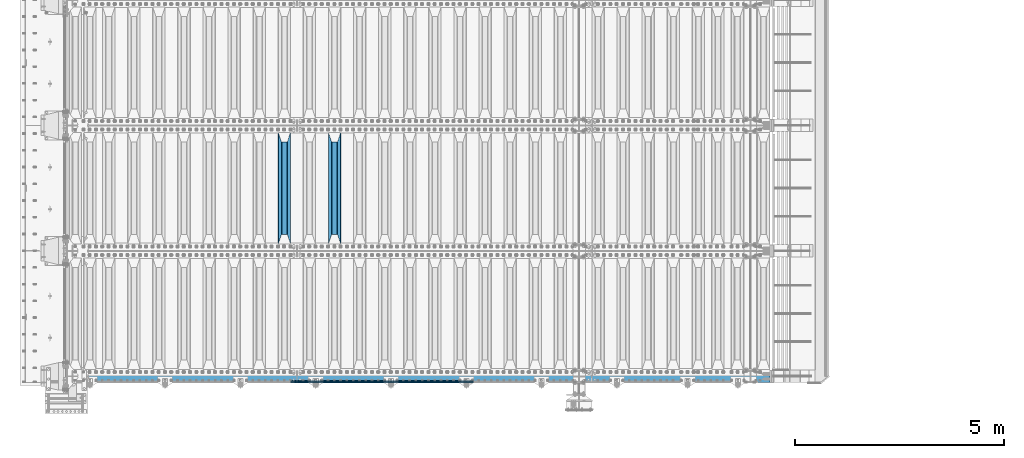
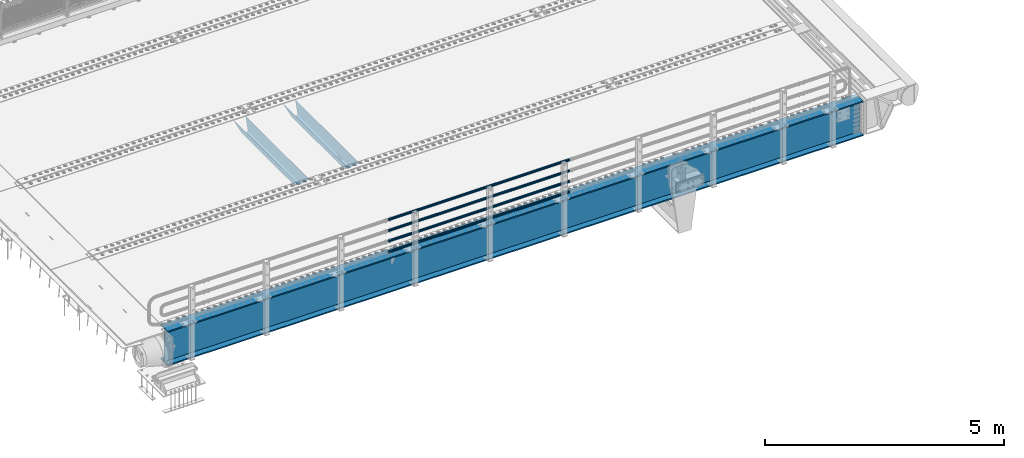
# One storey, part 106 of 257: 7 beams.
"""IFC2X3 building model written with IfcOpenShell, lengths in millimetres."""

import ifcopenshell
import ifcopenshell.guid

model = None  # the IFC model being written
_history = None  # IfcOwnerHistory: only IFC2X3 demands one
_inside = {}  # id of a spatial element -> (the spatial element, [elements in it])
_under = {}  # id of a project, library or spatial element -> (it, [spatial elements below it])
_declared = {}  # id of a project -> (the project, [libraries it declares])
_typed = {}  # id of a type object -> (the type object, [elements of that type])
_made_of = {}  # id of a material, layer set ... -> (it, [elements and type objects made of it])


def new_model(schema):
    """Start an empty IFC model of exactly this schema.

    Asked for "IFC4X3", IfcOpenShell would pick the latest addendum, in which some entities
    have other attributes; the version numbers below select the first issue.
    IFC2X3 requires an IfcOwnerHistory on every rooted entity: one is made here for all.
    """
    global model, _history
    if schema == "IFC4X3":
        model = ifcopenshell.file(schema_version=(4, 3, 0, 0))
    else:
        model = ifcopenshell.file(schema=schema)
    _inside.clear()
    _under.clear()
    _declared.clear()
    _typed.clear()
    _made_of.clear()
    _history = None
    if model.schema == "IFC2X3":
        org = make("IfcOrganization", Name="unknown")
        user = make(
            "IfcPersonAndOrganization",
            ThePerson=make("IfcPerson", FamilyName="unknown"),
            TheOrganization=org,
        )
        app = make(
            "IfcApplication",
            ApplicationDeveloper=org,
            Version="unknown",
            ApplicationFullName="unknown",
            ApplicationIdentifier="unknown",
        )
        _history = make(
            "IfcOwnerHistory",
            OwningUser=user,
            OwningApplication=app,
            ChangeAction="ADDED",
            CreationDate=0,
        )
    return model


def make(cls, **values):
    """One entity of the class cls with the attributes given. An attribute that is None is left unset."""
    return model.create_entity(
        cls, **{name: value for name, value in values.items() if value is not None}
    )


def rooted(cls, **values):
    """An entity with a GlobalId (a new one), such as an element, a storey or a relation."""
    return make(cls, GlobalId=ifcopenshell.guid.new(), OwnerHistory=_history, **values)


def si_unit(unit_type, name, prefix=None):
    """IfcSIUnit, for example si_unit("LENGTHUNIT", "METRE", prefix="MILLI")."""
    return make("IfcSIUnit", UnitType=unit_type, Prefix=prefix, Name=name)


def assignment(units):
    """IfcUnitAssignment: the units of a project."""
    return None if units is None else make("IfcUnitAssignment", Units=units)


def point(xyz):
    """IfcCartesianPoint."""
    return None if xyz is None else make("IfcCartesianPoint", Coordinates=xyz)


def direction(xyz):
    """IfcDirection."""
    return None if xyz is None else make("IfcDirection", DirectionRatios=xyz)


def frame(location, z_axis=None, x_axis=None):
    """IfcAxis2Placement3D, a coordinate frame: its origin and axes. An axis left out is left unset."""
    return make(
        "IfcAxis2Placement3D",
        Location=point(location),
        Axis=direction(z_axis),
        RefDirection=direction(x_axis),
    )


def origin_with_axes():
    """The frame at (0, 0, 0) with the z axis (0, 0, 1) and the x axis (1, 0, 0) written out."""
    return frame((0.0, 0.0, 0.0), z_axis=(0.0, 0.0, 1.0), x_axis=(1.0, 0.0, 0.0))


def place(relative_to, where):
    """IfcLocalPlacement: puts the frame where relative to a parent placement (None: the world)."""
    return make(
        "IfcLocalPlacement", PlacementRelTo=relative_to, RelativePlacement=where
    )


def context(
    kind, dimensions, precision=None, world=None, true_north=None, identifier=None
):
    """IfcGeometricRepresentationContext, for example the 3D "Model" context."""
    return make(
        "IfcGeometricRepresentationContext",
        ContextIdentifier=identifier,
        ContextType=kind,
        CoordinateSpaceDimension=dimensions,
        Precision=precision,
        WorldCoordinateSystem=world,
        TrueNorth=true_north,
    )


def subcontext(parent, identifier, kind, view, scale=None):
    """IfcGeometricRepresentationSubContext, for example "Body" below "Model"."""
    return make(
        "IfcGeometricRepresentationSubContext",
        ContextIdentifier=identifier,
        ContextType=kind,
        ParentContext=parent,
        TargetScale=scale,
        TargetView=view,
    )


def project(units=None, contexts=None):
    """IfcProject with its units and contexts."""
    return rooted(
        "IfcProject",
        Name="project",
        RepresentationContexts=contexts,
        UnitsInContext=assignment(units),
    )


def spatial(cls, under=None, at=None, **own):
    """A site, building, storey or space (cls), placed at a placement, below another one or the project."""
    s = rooted(cls, ObjectPlacement=at, **own)
    if under is not None:
        _under.setdefault(under.id(), (under, []))[1].append(s)
    return s


def faces_of(points, faces, orient=None, outer=None):
    """IfcFace entities. A face is a list of loops; a loop is a list of indices into points, from 0.

    orient and outer hold one flag for each loop. By default every Orientation is true, the
    first loop of a face is its IfcFaceOuterBound and the others are IfcFaceBound.
    """
    made = []
    for i, loops in enumerate(faces):
        bounds = []
        for j, loop in enumerate(loops):
            is_outer = j == 0 if outer is None else outer[i][j]
            bounds.append(
                make(
                    "IfcFaceOuterBound" if is_outer else "IfcFaceBound",
                    Bound=make("IfcPolyLoop", Polygon=[points[k] for k in loop]),
                    Orientation=True if orient is None else orient[i][j],
                )
            )
        made.append(make("IfcFace", Bounds=bounds))
    return made


def faceted_brep(points, faces, orient=None, outer=None, voids=None):
    """IfcFacetedBrep: a solid bounded by flat faces; with voids (closed shells), ...WithVoids."""
    shared = [point(p) for p in points]
    hull = make("IfcClosedShell", CfsFaces=faces_of(shared, faces, orient, outer))
    if voids is None:
        return make("IfcFacetedBrep", Outer=hull)
    return make(
        "IfcFacetedBrepWithVoids",
        Outer=hull,
        Voids=[
            make(cls, CfsFaces=faces_of(shared, fs, o, b)) for cls, fs, o, b in voids
        ],
    )


def shape(context_of_items, identifier, shape_type, items):
    """IfcShapeRepresentation: the items that make up one representation, for example the "Body"."""
    return make(
        "IfcShapeRepresentation",
        ContextOfItems=context_of_items,
        RepresentationIdentifier=identifier,
        RepresentationType=shape_type,
        Items=items,
    )


def material(Name=None, Category=None):
    """IfcMaterial."""
    return make("IfcMaterial", Name=Name, Category=Category)


def made_of(thing, what):
    """Note that an element or type object is made of a material, layer set ...; save() writes the relation."""
    if what is not None:
        _made_of.setdefault(what.id(), (what, []))[1].append(thing)
    return thing


def type_object(cls, material=None, **own):
    """A type object (cls), such as IfcWallType, which elements share."""
    return made_of(rooted(cls, **own), material)


def element(
    cls,
    number,
    at=None,
    inside=None,
    cuts=None,
    type_object=None,
    material=None,
    context=None,
    identifier="Body",
    shape_type=None,
    held_by="IfcProductDefinitionShape",
    body=None,
    shapes=None,
    **own,
):
    """One element of the class cls, such as IfcWall. Its Tag is "e" and its number.

    at: its placement. inside: the storey or other place that contains it. cuts: it is an
    opening in that element (IfcRelVoidsElement). A single representation is given by context,
    identifier, shape_type and body (its items); several are given by shapes. held_by: the class
    of the entity that holds the representations. save() writes the other relations.
    """
    e = rooted(cls, Tag="e%d" % number, ObjectPlacement=at, **own)
    if body is not None:
        shapes = [shape(context, identifier, shape_type, body)]
    if shapes is not None:
        e.Representation = make(held_by, Representations=shapes)
    if inside is not None:
        _inside.setdefault(inside.id(), (inside, []))[1].append(e)
    if cuts is not None:
        rooted(
            "IfcRelVoidsElement", RelatingBuildingElement=cuts, RelatedOpeningElement=e
        )
    if type_object is not None:
        _typed.setdefault(type_object.id(), (type_object, []))[1].append(e)
    return made_of(e, material)


def aggregate(whole, parts):
    """IfcRelAggregates: a whole, such as a stair, and the parts it consists of."""
    return rooted("IfcRelAggregates", RelatingObject=whole, RelatedObjects=parts)


def save(model, path):
    """Write the relations noted so far, then the file.

    IfcRelAggregates (storeys below a building ...), IfcRelContainedInSpatialStructure (elements
    in a storey), IfcRelDefinesByType, IfcRelAssociatesMaterial and IfcRelDeclares: one each for
    every whole, place, type object, material and project.
    """
    for whole, parts in _under.values():
        aggregate(whole, parts)
    for where, things in _inside.values():
        rooted(
            "IfcRelContainedInSpatialStructure",
            RelatedElements=things,
            RelatingStructure=where,
        )
    for kind, things in _typed.values():
        rooted("IfcRelDefinesByType", RelatedObjects=things, RelatingType=kind)
    for what, things in _made_of.values():
        rooted("IfcRelAssociatesMaterial", RelatedObjects=things, RelatingMaterial=what)
    for by, libraries in _declared.values():
        rooted("IfcRelDeclares", RelatingContext=by, RelatedDefinitions=libraries)
    model.write(path)


model = new_model("IFC2X3")

# Units and contexts
model_context = context("Model", 3, precision=1e-05, world=origin_with_axes())
body_context = subcontext(model_context, "Body", "Model", "MODEL_VIEW")
ifc_project = project(units=[si_unit("LENGTHUNIT", "METRE", prefix="MILLI"), si_unit("AREAUNIT", "SQUARE_METRE"), si_unit("VOLUMEUNIT", "CUBIC_METRE"), si_unit("MASSUNIT", "GRAM", prefix="KILO"), si_unit("TIMEUNIT", "SECOND"), si_unit("PLANEANGLEUNIT", "RADIAN"), si_unit("SOLIDANGLEUNIT", "STERADIAN"), si_unit("THERMODYNAMICTEMPERATUREUNIT", "DEGREE_CELSIUS"), si_unit("LUMINOUSINTENSITYUNIT", "LUMEN")], contexts=[model_context])

# Site, building, storey
site_placement = place(None, origin_with_axes())
site = spatial("IfcSite", under=ifc_project, at=site_placement, CompositionType="ELEMENT")
building_placement = place(site_placement, origin_with_axes())
building = spatial("IfcBuilding", under=site, at=building_placement, Name="Standard", CompositionType="ELEMENT")
storey_placement = place(building_placement, origin_with_axes())
storey = spatial("IfcBuildingStorey", under=building, at=storey_placement, Name="Undefined", CompositionType="ELEMENT", Elevation=0.0)

# Beams
ifc_material_1 = material(Name="STEEL/S355N")
beam_type_1 = type_object("IfcBeamType", PredefinedType="NOTDEFINED")
beam_1_placement = place(storey_placement, frame((48850.0, 3175.0, -115.0), z_axis=(0.0, 0.0, 1.0), x_axis=(0.0, 1.0, 0.0)))
element("IfcBeam", 1, at=beam_1_placement, inside=storey, type_object=beam_type_1, material=ifc_material_1, context=body_context, shape_type="Brep", body=[
    faceted_brep([(0.0, 150.0, 115.0), (0.0, 143.690000000002, 115.0), (2650.00000000297, 143.690000000002, 115.0), (2650.00000000297, 150.0, 115.0), (2650.00000000297, 142.059565218406, 110.0000000031), (2650.00000000297, 148.369565218403, 110.0000000031), (2441.90079219208, -80.1103600731149, -98.0992078077845), (2437.7588105432, -77.5672621345584, -102.241189456673), (2434.06523489746, -74.4080125315522, -105.934765102404), (2430.91086095089, -70.7102721255724, -109.089139048974), (2428.37322971128, -66.5649389910031, -111.626770288588), (2426.51472138055, -62.0739139532889, -113.485278619323), (2425.38102192091, -57.3475956567636, -114.618978078955), (2424.99999999987, -52.5021667386536, -115.0), (2424.99999999987, 52.5021667386536, -115.0), (2425.38102192091, 57.3475956567636, -114.618978078955), (2426.51472138055, 62.0739139532889, -113.485278619323), (2428.37322971128, 66.5649389910031, -111.626770288588), (2430.91086095089, 70.7102721255724, -109.089139048974), (2434.06523489746, 74.4080125315522, -105.934765102404), (2437.7588105432, 77.5672621345584, -102.241189456673), (2441.90079219208, 80.1103600731149, -98.0992078077846), (2446.38936140511, 81.9747917625791, -93.6106385947584), (2448.24948500409, 76.2713538057287, -91.7505149957729), (2444.62967112262, 74.76777986261, -95.3703288772456), (2441.28936334126, 72.7168944282894, -98.710636658607), (2438.31067330438, 70.1691124903809, -101.689326695487), (2435.76682334747, 67.1870637758839, -104.233176652398), (2433.72034654133, 63.8440531834931, -106.279653458539), (2432.22154950041, 60.2222587982324, -107.778450499454), (2431.30727574265, 56.4107117849126, -108.692724257221), (2430.99999999987, 52.5031078186876, -109.0), (2430.99999999987, -52.5031078186876, -109.0), (2431.30727574265, -56.4107117849126, -108.692724257221), (2432.22154950041, -60.2222587982324, -107.778450499454), (2433.72034654133, -63.8440531834931, -106.279653458539), (2435.76682334747, -67.1870637758839, -104.233176652398), (2438.31067330438, -70.1691124903809, -101.689326695487), (2441.28936334126, -72.7168944282894, -98.7106366586071), (2444.62967112262, -74.76777986261, -95.3703288772457), (2448.24948500409, -76.2713538057287, -91.7505149957729), (2650.00000000297, -142.059565218406, 110.0000000031), (2650.00000000297, -148.369565218403, 110.0000000031), (2446.38936140511, -81.9747917625791, -93.6106385947584), (2650.00000000297, -143.690000000002, 115.0), (2650.00000000297, -150.0, 115.0), (0.0, -143.690000000002, 115.0), (0.0, -150.0, 115.0), (0.0, -148.369565218258, 110.000000002662), (203.61063859742, -81.9747917625791, -93.6106385947584), (208.099207810447, -80.1103600731149, -98.0992078077845), (212.241189459335, -77.5672621345584, -102.241189456673), (215.934765105066, -74.4080125315522, -105.934765102404), (219.089139051636, -70.7102721255724, -109.089139048974), (221.626770291251, -66.5649389910031, -111.626770288588), (223.485278621985, -62.0739139532889, -113.485278619323), (224.618978081617, -57.3475956567636, -114.618978078955), (225.000000002662, -52.5021667386536, -115.0), (225.000000002662, 52.5021667386536, -115.0), (224.618978081617, 57.3475956567636, -114.618978078955), (223.485278621985, 62.0739139532889, -113.485278619323), (221.626770291251, 66.5649389910031, -111.626770288588), (219.089139051636, 70.7102721255724, -109.089139048974), (215.934765105066, 74.4080125315522, -105.934765102404), (212.241189459335, 77.5672621345584, -102.241189456673), (208.099207810447, 80.1103600731149, -98.0992078077846), (203.61063859742, 81.9747917625791, -93.6106385947584), (0.0, 148.369565218258, 110.000000002662), (0.0, 142.05956521826, 110.000000002662), (201.750514998435, 76.2713538057287, -91.7505149957729), (205.370328879908, 74.76777986261, -95.3703288772456), (208.710636661269, 72.7168944282894, -98.710636658607), (211.689326698149, 70.1691124903809, -101.689326695487), (214.233176655061, 67.1870637758839, -104.233176652398), (216.279653461201, 63.8440531834931, -106.279653458539), (217.778450502116, 60.2222587982324, -107.778450499454), (218.692724259884, 56.4107117849126, -108.692724257221), (219.000000002662, 52.5031078186876, -109.0), (219.000000002662, -52.5031078186876, -109.0), (218.692724259884, -56.4107117849126, -108.692724257221), (217.778450502116, -60.2222587982324, -107.778450499454), (216.279653461201, -63.8440531834931, -106.279653458539), (214.233176655061, -67.1870637758839, -104.233176652398), (211.689326698149, -70.1691124903809, -101.689326695487), (208.710636661269, -72.7168944282894, -98.7106366586071), (205.370328879908, -74.76777986261, -95.3703288772457), (201.750514998435, -76.2713538057287, -91.7505149957729), (0.0, -142.05956521826, 110.000000002662)], [[[0, 1, 2, 3]], [[3, 2, 4, 5]], [[6, 7, 8, 9, 10, 11, 12, 13, 14, 15, 16, 17, 18, 19, 20, 21, 22, 5, 4, 23, 24, 25, 26, 27, 28, 29, 30, 31, 32, 33, 34, 35, 36, 37, 38, 39, 40, 41, 42, 43]], [[44, 45, 42, 41]], [[46, 47, 45, 44]], [[43, 42, 45, 47, 48, 49]], [[6, 43, 49, 50]], [[7, 6, 50, 51]], [[8, 7, 51, 52]], [[9, 8, 52, 53]], [[10, 9, 53, 54]], [[11, 10, 54, 55]], [[12, 11, 55, 56]], [[13, 12, 56, 57]], [[14, 13, 57, 58]], [[15, 14, 58, 59]], [[16, 15, 59, 60]], [[17, 16, 60, 61]], [[18, 17, 61, 62]], [[19, 18, 62, 63]], [[20, 19, 63, 64]], [[21, 20, 64, 65]], [[22, 21, 65, 66]], [[0, 3, 5, 22, 66, 67]], [[1, 0, 67, 68]], [[23, 4, 2, 1, 68, 69]], [[24, 23, 69, 70]], [[25, 24, 70, 71]], [[26, 25, 71, 72]], [[27, 26, 72, 73]], [[28, 27, 73, 74]], [[29, 28, 74, 75]], [[30, 29, 75, 76]], [[31, 30, 76, 77]], [[32, 31, 77, 78]], [[33, 32, 78, 79]], [[34, 33, 79, 80]], [[35, 34, 80, 81]], [[36, 35, 81, 82]], [[37, 36, 82, 83]], [[38, 37, 83, 84]], [[39, 38, 84, 85]], [[40, 39, 85, 86]], [[46, 44, 41, 40, 86, 87]], [[47, 46, 87, 48]], [[86, 85, 84, 83, 82, 81, 80, 79, 78, 77, 76, 75, 74, 73, 72, 71, 70, 69, 68, 67, 66, 65, 64, 63, 62, 61, 60, 59, 58, 57, 56, 55, 54, 53, 52, 51, 50, 49, 48, 87]]]),
])
beam_2_placement = place(storey_placement, frame((47650.0, 3175.0, -115.0), z_axis=(0.0, 0.0, 1.0), x_axis=(0.0, 1.0, 0.0)))
element("IfcBeam", 2, at=beam_2_placement, inside=storey, type_object=beam_type_1, material=ifc_material_1, context=body_context, shape_type="Brep", body=[
    faceted_brep([(0.0, 150.0, 115.0), (0.0, 143.690000000002, 115.0), (2650.00000000297, 143.690000000002, 115.0), (2650.00000000297, 150.0, 115.0), (2650.00000000297, 142.059565218406, 110.0000000031), (2650.00000000297, 148.369565218403, 110.0000000031), (2441.90079219208, -80.1103600731149, -98.0992078077845), (2437.7588105432, -77.5672621345584, -102.241189456673), (2434.06523489746, -74.4080125315522, -105.934765102404), (2430.91086095089, -70.7102721255724, -109.089139048974), (2428.37322971128, -66.5649389910031, -111.626770288588), (2426.51472138055, -62.0739139532889, -113.485278619323), (2425.38102192091, -57.3475956567636, -114.618978078955), (2424.99999999987, -52.5021667386536, -115.0), (2424.99999999987, 52.5021667386536, -115.0), (2425.38102192091, 57.3475956567636, -114.618978078955), (2426.51472138055, 62.0739139532889, -113.485278619323), (2428.37322971128, 66.5649389910031, -111.626770288588), (2430.91086095089, 70.7102721255724, -109.089139048974), (2434.06523489746, 74.4080125315522, -105.934765102404), (2437.7588105432, 77.5672621345584, -102.241189456673), (2441.90079219208, 80.1103600731149, -98.0992078077846), (2446.38936140511, 81.9747917625791, -93.6106385947584), (2448.24948500409, 76.2713538057287, -91.7505149957729), (2444.62967112262, 74.76777986261, -95.3703288772456), (2441.28936334126, 72.7168944282894, -98.710636658607), (2438.31067330438, 70.1691124903809, -101.689326695487), (2435.76682334747, 67.1870637758839, -104.233176652398), (2433.72034654133, 63.8440531834931, -106.279653458539), (2432.22154950041, 60.2222587982324, -107.778450499454), (2431.30727574265, 56.4107117849126, -108.692724257221), (2430.99999999987, 52.5031078186876, -109.0), (2430.99999999987, -52.5031078186876, -109.0), (2431.30727574265, -56.4107117849126, -108.692724257221), (2432.22154950041, -60.2222587982324, -107.778450499454), (2433.72034654133, -63.8440531834931, -106.279653458539), (2435.76682334747, -67.1870637758839, -104.233176652398), (2438.31067330438, -70.1691124903809, -101.689326695487), (2441.28936334126, -72.7168944282894, -98.7106366586071), (2444.62967112262, -74.76777986261, -95.3703288772457), (2448.24948500409, -76.2713538057287, -91.7505149957729), (2650.00000000297, -142.059565218406, 110.0000000031), (2650.00000000297, -148.369565218403, 110.0000000031), (2446.38936140511, -81.9747917625791, -93.6106385947584), (2650.00000000297, -143.690000000002, 115.0), (2650.00000000297, -150.0, 115.0), (0.0, -143.690000000002, 115.0), (0.0, -150.0, 115.0), (0.0, -148.369565218258, 110.000000002662), (203.61063859742, -81.9747917625791, -93.6106385947584), (208.099207810447, -80.1103600731149, -98.0992078077845), (212.241189459335, -77.5672621345584, -102.241189456673), (215.934765105066, -74.4080125315522, -105.934765102404), (219.089139051636, -70.7102721255724, -109.089139048974), (221.626770291251, -66.5649389910031, -111.626770288588), (223.485278621985, -62.0739139532889, -113.485278619323), (224.618978081617, -57.3475956567636, -114.618978078955), (225.000000002662, -52.5021667386536, -115.0), (225.000000002662, 52.5021667386536, -115.0), (224.618978081617, 57.3475956567636, -114.618978078955), (223.485278621985, 62.0739139532889, -113.485278619323), (221.626770291251, 66.5649389910031, -111.626770288588), (219.089139051636, 70.7102721255724, -109.089139048974), (215.934765105066, 74.4080125315522, -105.934765102404), (212.241189459335, 77.5672621345584, -102.241189456673), (208.099207810447, 80.1103600731149, -98.0992078077846), (203.61063859742, 81.9747917625791, -93.6106385947584), (0.0, 148.369565218258, 110.000000002662), (0.0, 142.05956521826, 110.000000002662), (201.750514998435, 76.2713538057287, -91.7505149957729), (205.370328879908, 74.76777986261, -95.3703288772456), (208.710636661269, 72.7168944282894, -98.710636658607), (211.689326698149, 70.1691124903809, -101.689326695487), (214.233176655061, 67.1870637758839, -104.233176652398), (216.279653461201, 63.8440531834931, -106.279653458539), (217.778450502116, 60.2222587982324, -107.778450499454), (218.692724259884, 56.4107117849126, -108.692724257221), (219.000000002662, 52.5031078186876, -109.0), (219.000000002662, -52.5031078186876, -109.0), (218.692724259884, -56.4107117849126, -108.692724257221), (217.778450502116, -60.2222587982324, -107.778450499454), (216.279653461201, -63.8440531834931, -106.279653458539), (214.233176655061, -67.1870637758839, -104.233176652398), (211.689326698149, -70.1691124903809, -101.689326695487), (208.710636661269, -72.7168944282894, -98.7106366586071), (205.370328879908, -74.76777986261, -95.3703288772457), (201.750514998435, -76.2713538057287, -91.7505149957729), (0.0, -142.05956521826, 110.000000002662)], [[[0, 1, 2, 3]], [[3, 2, 4, 5]], [[6, 7, 8, 9, 10, 11, 12, 13, 14, 15, 16, 17, 18, 19, 20, 21, 22, 5, 4, 23, 24, 25, 26, 27, 28, 29, 30, 31, 32, 33, 34, 35, 36, 37, 38, 39, 40, 41, 42, 43]], [[44, 45, 42, 41]], [[46, 47, 45, 44]], [[43, 42, 45, 47, 48, 49]], [[6, 43, 49, 50]], [[7, 6, 50, 51]], [[8, 7, 51, 52]], [[9, 8, 52, 53]], [[10, 9, 53, 54]], [[11, 10, 54, 55]], [[12, 11, 55, 56]], [[13, 12, 56, 57]], [[14, 13, 57, 58]], [[15, 14, 58, 59]], [[16, 15, 59, 60]], [[17, 16, 60, 61]], [[18, 17, 61, 62]], [[19, 18, 62, 63]], [[20, 19, 63, 64]], [[21, 20, 64, 65]], [[22, 21, 65, 66]], [[0, 3, 5, 22, 66, 67]], [[1, 0, 67, 68]], [[23, 4, 2, 1, 68, 69]], [[24, 23, 69, 70]], [[25, 24, 70, 71]], [[26, 25, 71, 72]], [[27, 26, 72, 73]], [[28, 27, 73, 74]], [[29, 28, 74, 75]], [[30, 29, 75, 76]], [[31, 30, 76, 77]], [[32, 31, 77, 78]], [[33, 32, 78, 79]], [[34, 33, 79, 80]], [[35, 34, 80, 81]], [[36, 35, 81, 82]], [[37, 36, 82, 83]], [[38, 37, 83, 84]], [[39, 38, 84, 85]], [[40, 39, 85, 86]], [[46, 44, 41, 40, 86, 87]], [[47, 46, 87, 48]], [[86, 85, 84, 83, 82, 81, 80, 79, 78, 77, 76, 75, 74, 73, 72, 71, 70, 69, 68, 67, 66, 65, 64, 63, 62, 61, 60, 59, 58, 57, 56, 55, 54, 53, 52, 51, 50, 49, 48, 87]]]),
])
ifc_material_2 = material()
beam_type_2 = type_object("IfcBeamType", PredefinedType="NOTDEFINED")
beam_3_placement = place(storey_placement, frame((52177.9999999999, -129.849999999907, 149.849999999725), z_axis=(0.0, 0.0, -1.0), x_axis=(-1.0, 0.0, 0.0)))
element("IfcBeam", 3, at=beam_3_placement, inside=storey, type_object=beam_type_2, material=ifc_material_2, context=body_context, shape_type="Brep", body=[
    faceted_brep([(0.0, -26.5499999999993, 0.0), (0.0, -24.5290015881747, 10.1602451292931), (4384.00249699992, -24.5290015881747, 10.1602451292931), (4384.00249699992, -26.5499999999993, 0.0), (0.0, -18.7736850405036, 18.7736850405028), (4384.00249699992, -18.7736850405036, 18.7736850405028), (0.0, -10.1602451292929, 24.5290015881747), (4384.00249699992, -10.1602451292929, 24.5290015881747), (0.0, 0.0, 26.55), (4384.00249699992, 0.0, 26.55), (0.0, 10.1602451292929, 24.5290015881747), (4384.00249699992, 10.1602451292929, 24.5290015881747), (0.0, 18.7736850405036, 18.7736850405028), (4384.00249699992, 18.7736850405036, 18.7736850405028), (0.0, 24.5290015881747, 10.1602451292931), (4384.00249699992, 24.5290015881747, 10.1602451292931), (0.0, 26.5499999999993, 0.0), (4384.00249699992, 26.5499999999993, 0.0), (0.0, 24.5290015881747, -10.1602451292931), (4384.00249699992, 24.5290015881747, -10.1602451292931), (0.0, 18.7736850405036, -18.7736850405028), (4384.00249699992, 18.7736850405036, -18.7736850405028), (0.0, 10.1602451292929, -24.5290015881747), (4384.00249699992, 10.1602451292929, -24.5290015881747), (0.0, 0.0, -26.55), (4384.00249699992, 0.0, -26.55), (0.0, -10.1602451292929, -24.5290015881747), (4384.00249699992, -10.1602451292929, -24.5290015881747), (0.0, -18.7736850405036, -18.7736850405028), (4384.00249699992, -18.7736850405036, -18.7736850405028), (0.0, -24.5290015881747, -10.1602451292931), (4384.00249699992, -24.5290015881747, -10.1602451292931), (0.0, -30.1499999999996, 0.0), (0.0, -27.8549679052157, -11.5379054858058), (4384.00249699992, -27.8549679052157, -11.5379054858075), (4384.00249699992, -30.1499999999996, 0.0), (0.0, -21.3192694527752, -21.3192694527752), (4384.00249699992, -21.3192694527752, -21.3192694527744), (0.0, -11.5379054858076, -27.8549679052157), (4384.00249699992, -11.5379054858076, -27.8549679052153), (0.0, 0.0, -30.1500000000015), (4384.00249699992, 0.0, -30.15), (0.0, 11.5379054858076, -27.8549679052157), (4384.00249699992, 11.5379054858076, -27.8549679052153), (0.0, 21.3192694527752, -21.3192694527752), (4384.00249699992, 21.3192694527752, -21.3192694527744), (0.0, 27.8549679052157, -11.5379054858058), (4384.00249699992, 27.8549679052157, -11.5379054858074), (0.0, 30.1499999999996, 0.0), (4384.00249699992, 30.1499999999996, 0.0), (0.0, 27.8549679052157, 11.5379054858058), (4384.00249699992, 27.8549679052157, 11.5379054858075), (0.0, 21.3192694527752, 21.3192694527752), (4384.00249699992, 21.3192694527752, 21.3192694527744), (0.0, 11.5379054858076, 27.8549679052157), (4384.00249699992, 11.5379054858076, 27.8549679052153), (0.0, 0.0, 30.1500000000015), (4384.00249699992, 0.0, 30.15), (0.0, -11.5379054858076, 27.8549679052157), (4384.00249699992, -11.5379054858076, 27.8549679052153), (0.0, -21.3192694527752, 21.3192694527752), (4384.00249699992, -21.3192694527752, 21.3192694527744), (0.0, -27.8549679052157, 11.5379054858058), (4384.00249699992, -27.8549679052157, 11.5379054858075)], [[[0, 1, 2, 3]], [[1, 4, 5, 2]], [[4, 6, 7, 5]], [[6, 8, 9, 7]], [[8, 10, 11, 9]], [[10, 12, 13, 11]], [[12, 14, 15, 13]], [[14, 16, 17, 15]], [[16, 18, 19, 17]], [[18, 20, 21, 19]], [[20, 22, 23, 21]], [[22, 24, 25, 23]], [[24, 26, 27, 25]], [[26, 28, 29, 27]], [[28, 30, 31, 29]], [[30, 0, 3, 31]], [[32, 33, 34, 35]], [[33, 36, 37, 34]], [[36, 38, 39, 37]], [[38, 40, 41, 39]], [[40, 42, 43, 41]], [[42, 44, 45, 43]], [[44, 46, 47, 45]], [[46, 48, 49, 47]], [[48, 50, 51, 49]], [[50, 52, 53, 51]], [[52, 54, 55, 53]], [[54, 56, 57, 55]], [[56, 58, 59, 57]], [[58, 60, 61, 59]], [[60, 62, 63, 61]], [[62, 32, 35, 63]], [[37, 39, 41, 43, 45, 47, 49, 51, 53, 55, 57, 59, 61, 63, 35, 34], [5, 7, 9, 11, 13, 15, 17, 19, 21, 23, 25, 27, 29, 31, 3, 2]], [[62, 60, 58, 56, 54, 52, 50, 48, 46, 44, 42, 40, 38, 36, 33, 32], [30, 28, 26, 24, 22, 20, 18, 16, 14, 12, 10, 8, 6, 4, 1, 0]]]),
])
beam_4_placement = place(storey_placement, frame((52177.9999999999, -129.849999999907, 420.149999999728), z_axis=(0.0, 0.0, -1.0), x_axis=(-1.0, 0.0, 0.0)))
element("IfcBeam", 4, at=beam_4_placement, inside=storey, type_object=beam_type_2, material=ifc_material_2, context=body_context, shape_type="Brep", body=[
    faceted_brep([(0.0, -26.5499999999993, 0.0), (0.0, -24.5290015881747, 10.1602451292931), (4384.00249699992, -24.5290015881747, 10.1602451292931), (4384.00249699992, -26.5499999999993, 0.0), (0.0, -18.7736850405036, 18.7736850405028), (4384.00249699992, -18.7736850405036, 18.7736850405028), (0.0, -10.1602451292929, 24.5290015881747), (4384.00249699992, -10.1602451292929, 24.5290015881747), (0.0, 0.0, 26.55), (4384.00249699992, 0.0, 26.55), (0.0, 10.1602451292929, 24.5290015881747), (4384.00249699992, 10.1602451292929, 24.5290015881747), (0.0, 18.7736850405036, 18.7736850405028), (4384.00249699992, 18.7736850405036, 18.7736850405028), (0.0, 24.5290015881747, 10.1602451292931), (4384.00249699992, 24.5290015881747, 10.1602451292931), (0.0, 26.5499999999993, 0.0), (4384.00249699992, 26.5499999999993, 0.0), (0.0, 24.5290015881747, -10.1602451292931), (4384.00249699992, 24.5290015881747, -10.1602451292931), (0.0, 18.7736850405036, -18.7736850405028), (4384.00249699992, 18.7736850405036, -18.7736850405028), (0.0, 10.1602451292929, -24.5290015881747), (4384.00249699992, 10.1602451292929, -24.5290015881747), (0.0, 0.0, -26.55), (4384.00249699992, 0.0, -26.55), (0.0, -10.1602451292929, -24.5290015881747), (4384.00249699992, -10.1602451292929, -24.5290015881747), (0.0, -18.7736850405036, -18.7736850405028), (4384.00249699992, -18.7736850405036, -18.7736850405028), (0.0, -24.5290015881747, -10.1602451292931), (4384.00249699992, -24.5290015881747, -10.1602451292931), (0.0, -30.1499999999996, 0.0), (0.0, -27.8549679052157, -11.5379054858058), (4384.00249699992, -27.8549679052157, -11.5379054858075), (4384.00249699992, -30.1499999999996, 0.0), (0.0, -21.3192694527752, -21.3192694527752), (4384.00249699992, -21.3192694527752, -21.3192694527744), (0.0, -11.5379054858076, -27.8549679052157), (4384.00249699992, -11.5379054858076, -27.8549679052153), (0.0, 0.0, -30.1500000000015), (4384.00249699992, 0.0, -30.15), (0.0, 11.5379054858076, -27.8549679052157), (4384.00249699992, 11.5379054858076, -27.8549679052153), (0.0, 21.3192694527752, -21.3192694527752), (4384.00249699992, 21.3192694527752, -21.3192694527744), (0.0, 27.8549679052157, -11.5379054858058), (4384.00249699992, 27.8549679052157, -11.5379054858074), (0.0, 30.1499999999996, 0.0), (4384.00249699992, 30.1499999999996, 0.0), (0.0, 27.8549679052157, 11.5379054858058), (4384.00249699992, 27.8549679052157, 11.5379054858075), (0.0, 21.3192694527752, 21.3192694527752), (4384.00249699992, 21.3192694527752, 21.3192694527744), (0.0, 11.5379054858076, 27.8549679052157), (4384.00249699992, 11.5379054858076, 27.8549679052153), (0.0, 0.0, 30.1500000000015), (4384.00249699992, 0.0, 30.15), (0.0, -11.5379054858076, 27.8549679052157), (4384.00249699992, -11.5379054858076, 27.8549679052153), (0.0, -21.3192694527752, 21.3192694527752), (4384.00249699992, -21.3192694527752, 21.3192694527744), (0.0, -27.8549679052157, 11.5379054858058), (4384.00249699992, -27.8549679052157, 11.5379054858075)], [[[0, 1, 2, 3]], [[1, 4, 5, 2]], [[4, 6, 7, 5]], [[6, 8, 9, 7]], [[8, 10, 11, 9]], [[10, 12, 13, 11]], [[12, 14, 15, 13]], [[14, 16, 17, 15]], [[16, 18, 19, 17]], [[18, 20, 21, 19]], [[20, 22, 23, 21]], [[22, 24, 25, 23]], [[24, 26, 27, 25]], [[26, 28, 29, 27]], [[28, 30, 31, 29]], [[30, 0, 3, 31]], [[32, 33, 34, 35]], [[33, 36, 37, 34]], [[36, 38, 39, 37]], [[38, 40, 41, 39]], [[40, 42, 43, 41]], [[42, 44, 45, 43]], [[44, 46, 47, 45]], [[46, 48, 49, 47]], [[48, 50, 51, 49]], [[50, 52, 53, 51]], [[52, 54, 55, 53]], [[54, 56, 57, 55]], [[56, 58, 59, 57]], [[58, 60, 61, 59]], [[60, 62, 63, 61]], [[62, 32, 35, 63]], [[37, 39, 41, 43, 45, 47, 49, 51, 53, 55, 57, 59, 61, 63, 35, 34], [5, 7, 9, 11, 13, 15, 17, 19, 21, 23, 25, 27, 29, 31, 3, 2]], [[62, 60, 58, 56, 54, 52, 50, 48, 46, 44, 42, 40, 38, 36, 33, 32], [30, 28, 26, 24, 22, 20, 18, 16, 14, 12, 10, 8, 6, 4, 1, 0]]]),
])
beam_5_placement = place(storey_placement, frame((52177.9999999999, -129.849999999907, 969.849999999725), z_axis=(0.0, 0.0, -1.0), x_axis=(-1.0, 0.0, 0.0)))
element("IfcBeam", 5, at=beam_5_placement, inside=storey, type_object=beam_type_2, material=ifc_material_2, context=body_context, shape_type="Brep", body=[
    faceted_brep([(0.0, -26.5499999999993, 0.0), (0.0, -24.5290015881747, 10.1602451292931), (4384.00249699992, -24.5290015881747, 10.1602451292931), (4384.00249699992, -26.5499999999993, 0.0), (0.0, -18.7736850405036, 18.7736850405028), (4384.00249699992, -18.7736850405036, 18.7736850405028), (0.0, -10.1602451292929, 24.5290015881747), (4384.00249699992, -10.1602451292929, 24.5290015881747), (0.0, 0.0, 26.55), (4384.00249699992, 0.0, 26.55), (0.0, 10.1602451292929, 24.5290015881747), (4384.00249699992, 10.1602451292929, 24.5290015881747), (0.0, 18.7736850405036, 18.7736850405028), (4384.00249699992, 18.7736850405036, 18.7736850405028), (0.0, 24.5290015881747, 10.1602451292931), (4384.00249699992, 24.5290015881747, 10.1602451292931), (0.0, 26.5499999999993, 0.0), (4384.00249699992, 26.5499999999993, 0.0), (0.0, 24.5290015881747, -10.1602451292931), (4384.00249699992, 24.5290015881747, -10.1602451292931), (0.0, 18.7736850405036, -18.7736850405028), (4384.00249699992, 18.7736850405036, -18.7736850405028), (0.0, 10.1602451292929, -24.5290015881747), (4384.00249699992, 10.1602451292929, -24.5290015881747), (0.0, 0.0, -26.55), (4384.00249699992, 0.0, -26.55), (0.0, -10.1602451292929, -24.5290015881747), (4384.00249699992, -10.1602451292929, -24.5290015881747), (0.0, -18.7736850405036, -18.7736850405028), (4384.00249699992, -18.7736850405036, -18.7736850405028), (0.0, -24.5290015881747, -10.1602451292931), (4384.00249699992, -24.5290015881747, -10.1602451292931), (0.0, -30.1499999999996, 0.0), (0.0, -27.8549679052157, -11.5379054858058), (4384.00249699992, -27.8549679052157, -11.5379054858075), (4384.00249699992, -30.1499999999996, 0.0), (0.0, -21.3192694527752, -21.3192694527752), (4384.00249699992, -21.3192694527752, -21.3192694527744), (0.0, -11.5379054858076, -27.8549679052157), (4384.00249699992, -11.5379054858076, -27.8549679052153), (0.0, 0.0, -30.1500000000015), (4384.00249699992, 0.0, -30.15), (0.0, 11.5379054858076, -27.8549679052157), (4384.00249699992, 11.5379054858076, -27.8549679052153), (0.0, 21.3192694527752, -21.3192694527752), (4384.00249699992, 21.3192694527752, -21.3192694527744), (0.0, 27.8549679052157, -11.5379054858058), (4384.00249699992, 27.8549679052157, -11.5379054858074), (0.0, 30.1499999999996, 0.0), (4384.00249699992, 30.1499999999996, 0.0), (0.0, 27.8549679052157, 11.5379054858058), (4384.00249699992, 27.8549679052157, 11.5379054858075), (0.0, 21.3192694527752, 21.3192694527752), (4384.00249699992, 21.3192694527752, 21.3192694527744), (0.0, 11.5379054858076, 27.8549679052157), (4384.00249699992, 11.5379054858076, 27.8549679052153), (0.0, 0.0, 30.1500000000015), (4384.00249699992, 0.0, 30.15), (0.0, -11.5379054858076, 27.8549679052157), (4384.00249699992, -11.5379054858076, 27.8549679052153), (0.0, -21.3192694527752, 21.3192694527752), (4384.00249699992, -21.3192694527752, 21.3192694527744), (0.0, -27.8549679052157, 11.5379054858058), (4384.00249699992, -27.8549679052157, 11.5379054858075)], [[[0, 1, 2, 3]], [[1, 4, 5, 2]], [[4, 6, 7, 5]], [[6, 8, 9, 7]], [[8, 10, 11, 9]], [[10, 12, 13, 11]], [[12, 14, 15, 13]], [[14, 16, 17, 15]], [[16, 18, 19, 17]], [[18, 20, 21, 19]], [[20, 22, 23, 21]], [[22, 24, 25, 23]], [[24, 26, 27, 25]], [[26, 28, 29, 27]], [[28, 30, 31, 29]], [[30, 0, 3, 31]], [[32, 33, 34, 35]], [[33, 36, 37, 34]], [[36, 38, 39, 37]], [[38, 40, 41, 39]], [[40, 42, 43, 41]], [[42, 44, 45, 43]], [[44, 46, 47, 45]], [[46, 48, 49, 47]], [[48, 50, 51, 49]], [[50, 52, 53, 51]], [[52, 54, 55, 53]], [[54, 56, 57, 55]], [[56, 58, 59, 57]], [[58, 60, 61, 59]], [[60, 62, 63, 61]], [[62, 32, 35, 63]], [[37, 39, 41, 43, 45, 47, 49, 51, 53, 55, 57, 59, 61, 63, 35, 34], [5, 7, 9, 11, 13, 15, 17, 19, 21, 23, 25, 27, 29, 31, 3, 2]], [[62, 60, 58, 56, 54, 52, 50, 48, 46, 44, 42, 40, 38, 36, 33, 32], [30, 28, 26, 24, 22, 20, 18, 16, 14, 12, 10, 8, 6, 4, 1, 0]]]),
])
beam_6_placement = place(storey_placement, frame((52177.9999999999, -129.849999999907, 689.849999999725), z_axis=(0.0, 0.0, -1.0), x_axis=(-1.0, 0.0, 0.0)))
element("IfcBeam", 6, at=beam_6_placement, inside=storey, type_object=beam_type_2, material=ifc_material_2, context=body_context, shape_type="Brep", body=[
    faceted_brep([(0.0, -26.5499999999993, 0.0), (0.0, -24.5290015881747, 10.1602451292931), (4384.00249699992, -24.5290015881747, 10.1602451292931), (4384.00249699992, -26.5499999999993, 0.0), (0.0, -18.7736850405036, 18.7736850405028), (4384.00249699992, -18.7736850405036, 18.7736850405028), (0.0, -10.1602451292929, 24.5290015881747), (4384.00249699992, -10.1602451292929, 24.5290015881747), (0.0, 0.0, 26.55), (4384.00249699992, 0.0, 26.55), (0.0, 10.1602451292929, 24.5290015881747), (4384.00249699992, 10.1602451292929, 24.5290015881747), (0.0, 18.7736850405036, 18.7736850405028), (4384.00249699992, 18.7736850405036, 18.7736850405028), (0.0, 24.5290015881747, 10.1602451292931), (4384.00249699992, 24.5290015881747, 10.1602451292931), (0.0, 26.5499999999993, 0.0), (4384.00249699992, 26.5499999999993, 0.0), (0.0, 24.5290015881747, -10.1602451292931), (4384.00249699992, 24.5290015881747, -10.1602451292931), (0.0, 18.7736850405036, -18.7736850405028), (4384.00249699992, 18.7736850405036, -18.7736850405028), (0.0, 10.1602451292929, -24.5290015881747), (4384.00249699992, 10.1602451292929, -24.5290015881747), (0.0, 0.0, -26.55), (4384.00249699992, 0.0, -26.55), (0.0, -10.1602451292929, -24.5290015881747), (4384.00249699992, -10.1602451292929, -24.5290015881747), (0.0, -18.7736850405036, -18.7736850405028), (4384.00249699992, -18.7736850405036, -18.7736850405028), (0.0, -24.5290015881747, -10.1602451292931), (4384.00249699992, -24.5290015881747, -10.1602451292931), (0.0, -30.1499999999996, 0.0), (0.0, -27.8549679052157, -11.5379054858058), (4384.00249699992, -27.8549679052157, -11.5379054858075), (4384.00249699992, -30.1499999999996, 0.0), (0.0, -21.3192694527752, -21.3192694527752), (4384.00249699992, -21.3192694527752, -21.3192694527744), (0.0, -11.5379054858076, -27.8549679052157), (4384.00249699992, -11.5379054858076, -27.8549679052153), (0.0, 0.0, -30.1500000000015), (4384.00249699992, 0.0, -30.15), (0.0, 11.5379054858076, -27.8549679052157), (4384.00249699992, 11.5379054858076, -27.8549679052153), (0.0, 21.3192694527752, -21.3192694527752), (4384.00249699992, 21.3192694527752, -21.3192694527744), (0.0, 27.8549679052157, -11.5379054858058), (4384.00249699992, 27.8549679052157, -11.5379054858074), (0.0, 30.1499999999996, 0.0), (4384.00249699992, 30.1499999999996, 0.0), (0.0, 27.8549679052157, 11.5379054858058), (4384.00249699992, 27.8549679052157, 11.5379054858075), (0.0, 21.3192694527752, 21.3192694527752), (4384.00249699992, 21.3192694527752, 21.3192694527744), (0.0, 11.5379054858076, 27.8549679052157), (4384.00249699992, 11.5379054858076, 27.8549679052153), (0.0, 0.0, 30.1500000000015), (4384.00249699992, 0.0, 30.15), (0.0, -11.5379054858076, 27.8549679052157), (4384.00249699992, -11.5379054858076, 27.8549679052153), (0.0, -21.3192694527752, 21.3192694527752), (4384.00249699992, -21.3192694527752, 21.3192694527744), (0.0, -27.8549679052157, 11.5379054858058), (4384.00249699992, -27.8549679052157, 11.5379054858075)], [[[0, 1, 2, 3]], [[1, 4, 5, 2]], [[4, 6, 7, 5]], [[6, 8, 9, 7]], [[8, 10, 11, 9]], [[10, 12, 13, 11]], [[12, 14, 15, 13]], [[14, 16, 17, 15]], [[16, 18, 19, 17]], [[18, 20, 21, 19]], [[20, 22, 23, 21]], [[22, 24, 25, 23]], [[24, 26, 27, 25]], [[26, 28, 29, 27]], [[28, 30, 31, 29]], [[30, 0, 3, 31]], [[32, 33, 34, 35]], [[33, 36, 37, 34]], [[36, 38, 39, 37]], [[38, 40, 41, 39]], [[40, 42, 43, 41]], [[42, 44, 45, 43]], [[44, 46, 47, 45]], [[46, 48, 49, 47]], [[48, 50, 51, 49]], [[50, 52, 53, 51]], [[52, 54, 55, 53]], [[54, 56, 57, 55]], [[56, 58, 59, 57]], [[58, 60, 61, 59]], [[60, 62, 63, 61]], [[62, 32, 35, 63]], [[37, 39, 41, 43, 45, 47, 49, 51, 53, 55, 57, 59, 61, 63, 35, 34], [5, 7, 9, 11, 13, 15, 17, 19, 21, 23, 25, 27, 29, 31, 3, 2]], [[62, 60, 58, 56, 54, 52, 50, 48, 46, 44, 42, 40, 38, 36, 33, 32], [30, 28, 26, 24, 22, 20, 18, 16, 14, 12, 10, 8, 6, 4, 1, 0]]]),
])
beam_type_3 = type_object("IfcBeamType", Name="HEA900", PredefinedType="NOTDEFINED")
beam_7_placement = place(storey_placement, frame((42460.0, 0.0, -445.0), z_axis=(0.0, 0.0, 1.0), x_axis=(1.0, 0.0, 0.0)))
element("IfcBeam", 7, at=beam_7_placement, inside=storey, type_object=beam_type_3, material=ifc_material_1, ObjectType="HEA900", context=body_context, shape_type="Brep", body=[
    faceted_brep([(0.0, 150.0, -445.0), (0.0, 150.0, -415.0), (16807.0, 150.0, -415.0), (16807.0, 150.0, -445.0), (0.0, 8.0, -415.0), (16807.0, 8.0, -415.0), (0.0, 8.0, 415.0), (16807.0, 8.0, 415.0), (0.0, 150.0, 415.0), (16807.0, 150.0, 415.0), (0.0, 150.0, 445.0), (16807.0, 150.0, 445.0), (0.0, -150.0, 445.0), (16807.0, -150.0, 445.0), (0.0, -150.0, 415.0), (16807.0, -150.0, 415.0), (0.0, -8.0, 415.0), (16807.0, -8.0, 415.0), (0.0, -8.0, -415.0), (16807.0, -8.0, -415.0), (0.0, -150.0, -415.0), (16807.0, -150.0, -415.0), (0.0, -150.0, -445.0), (16807.0, -150.0, -445.0)], [[[0, 1, 2, 3]], [[1, 4, 5, 2]], [[4, 6, 7, 5]], [[6, 8, 9, 7]], [[8, 10, 11, 9]], [[10, 12, 13, 11]], [[12, 14, 15, 13]], [[14, 16, 17, 15]], [[16, 18, 19, 17]], [[18, 20, 21, 19]], [[20, 22, 23, 21]], [[22, 0, 3, 23]], [[5, 7, 9, 11, 13, 15, 17, 19, 21, 23, 3, 2]], [[22, 20, 18, 16, 14, 12, 10, 8, 6, 4, 1, 0]]]),
])

save(model, "model.ifc")
